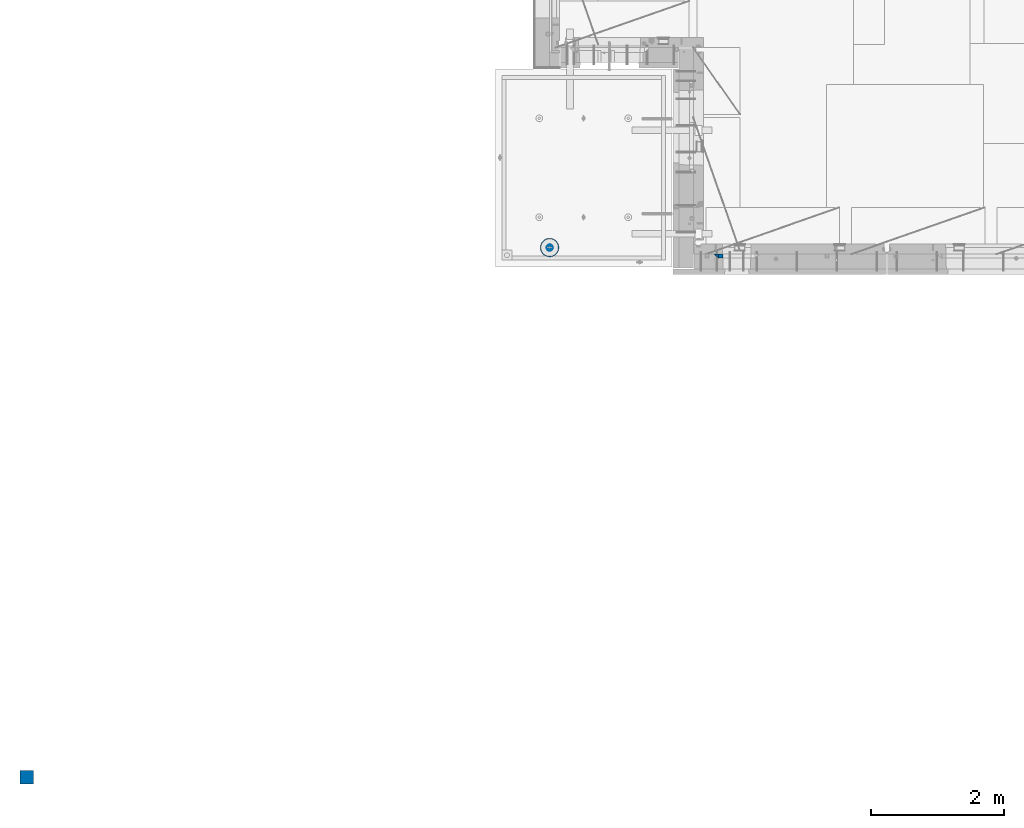
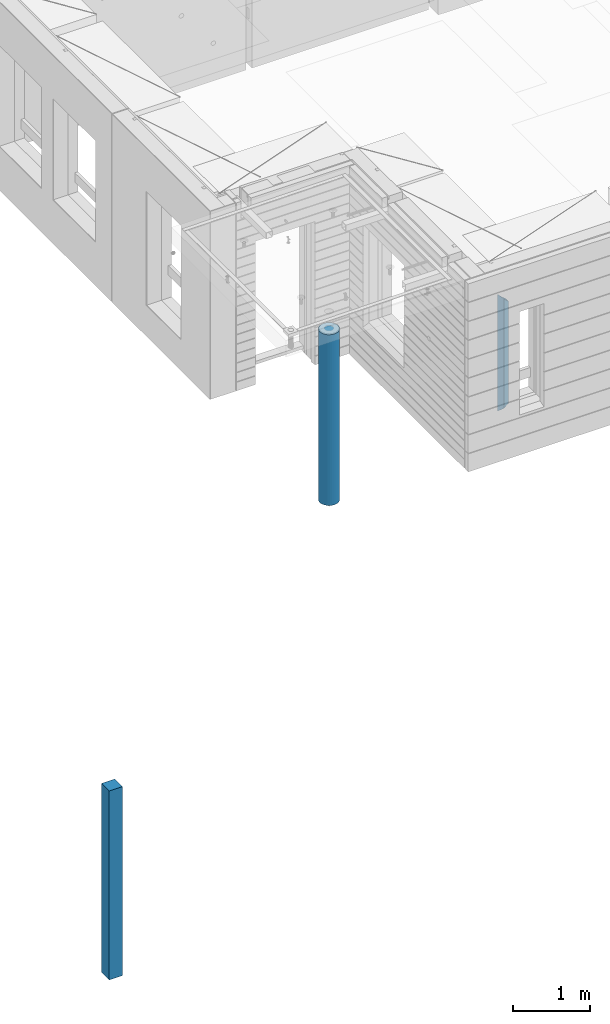
# One storey, part 1 of 341: 4 columns, 3 elements without a shape of their own.
"""IFC2X3 building model written with IfcOpenShell, lengths in millimetres."""

from ifc_helpers import new_model, si_unit, frame, origin_with_axes, place, context, subcontext, project, spatial, faceted_brep, material, type_object, element, aggregate, save


model = new_model("IFC2X3")

# Units and contexts
model_context = context("Model", 3, precision=1e-05, world=origin_with_axes())
body_context = subcontext(model_context, "Body", "Model", "MODEL_VIEW")
ifc_project = project(units=[si_unit("LENGTHUNIT", "METRE", prefix="MILLI"), si_unit("AREAUNIT", "SQUARE_METRE"), si_unit("VOLUMEUNIT", "CUBIC_METRE"), si_unit("MASSUNIT", "GRAM", prefix="KILO"), si_unit("TIMEUNIT", "SECOND"), si_unit("PLANEANGLEUNIT", "RADIAN"), si_unit("SOLIDANGLEUNIT", "STERADIAN"), si_unit("THERMODYNAMICTEMPERATUREUNIT", "DEGREE_CELSIUS"), si_unit("LUMINOUSINTENSITYUNIT", "LUMEN")], contexts=[model_context])

# Site, building, storey
site_placement = place(None, origin_with_axes())
site = spatial("IfcSite", under=ifc_project, at=site_placement, CompositionType="ELEMENT")
building_placement = place(site_placement, origin_with_axes())
building = spatial("IfcBuilding", under=site, at=building_placement, CompositionType="ELEMENT")
storey_placement = place(building_placement, origin_with_axes())
storey = spatial("IfcBuildingStorey", under=building, at=storey_placement, Name="5", CompositionType="ELEMENT", Elevation=0.0)

# Assembly, columns
assembly_1_placement = place(storey_placement, origin_with_axes())
assembly_1 = element("IfcElementAssembly", 1, at=assembly_1_placement, inside=storey, AssemblyPlace="NOTDEFINED", PredefinedType="REINFORCEMENT_UNIT")
ifc_material_1 = material(Name="CONCRETE/C25/30")
column_type_1 = type_object("IfcColumnType", PredefinedType="NOTDEFINED")
column_1_placement = place(assembly_1_placement, frame((10354.997879677, 7820.0, 94320.0), z_axis=(1.0, 0.0, 0.0), x_axis=(0.0, 0.0, 1.0)))
column_1 = element("IfcColumn", 2, at=column_1_placement, type_object=column_type_1, material=ifc_material_1, Name="SK", context=body_context, shape_type="Brep", body=[
    faceted_brep([(1795.00000000001, -30.0, 30.0), (1855.0, -30.0, -30.0), (1795.00000000001, 30.0, 30.0), (60.0000000000073, -30.0, 30.0), (0.0, -30.0, -30.0), (60.0000000000073, 30.0, 30.0)], [[[0, 1, 2]], [[1, 0, 3, 4]], [[2, 1, 4, 5]], [[0, 2, 5, 3]], [[5, 4, 3]]]),
])
column_type_2 = type_object("IfcColumnType", PredefinedType="NOTDEFINED")
column_2_placement = place(assembly_1_placement, frame((10419.997879677, 7820.0, 94380.0), z_axis=(1.0, 0.0, 0.0), x_axis=(0.0, 0.0, 1.0)))
column_2 = element("IfcColumn", 3, at=column_2_placement, type_object=column_type_2, material=ifc_material_1, Name="SK", context=body_context, shape_type="Brep", body=[
    faceted_brep([(1735.0, -30.0, -35.0), (1735.0, 30.0, -35.0), (1678.70525582272, 30.0, 30.6772015545812), (1680.09521721235, -30.0, 29.0555799329595), (56.2947441772849, 30.0, 30.6772015545812), (54.9047827876348, -30.0, 29.0555799329595), (0.0, -30.0, -35.0), (0.0, 30.0, -35.0)], [[[0, 1, 2, 3]], [[3, 2, 4, 5]], [[0, 3, 5, 6]], [[1, 0, 6, 7]], [[2, 1, 7, 4]], [[6, 5, 4, 7]]]),
])
aggregate(assembly_1, [column_1, column_2])

# Assembly, column
assembly_2_placement = place(storey_placement, origin_with_axes())
assembly_2 = element("IfcElementAssembly", 4, at=assembly_2_placement, inside=storey, AssemblyPlace="NOTDEFINED", PredefinedType="REINFORCEMENT_UNIT")
ifc_material_2 = material(Name="CONCRETE/Concrete_Undefined")
column_type_3 = type_object("IfcColumnType", PredefinedType="NOTDEFINED")
column_3_placement = place(assembly_2_placement, frame((0.0, 0.0, 93760.0), z_axis=(0.0, 1.0, 0.0), x_axis=(0.0, 0.0, 1.0)))
column_3 = element("IfcColumn", 5, at=column_3_placement, type_object=column_type_3, material=ifc_material_2, context=body_context, shape_type="Brep", body=[
    faceted_brep([(0.0, 100.0, -100.0), (0.0, 100.0, 100.0), (3000.0, 100.0, 100.0), (3000.0, 100.0, -100.0), (0.0, -100.0, 100.0), (3000.0, -100.0, 100.0), (0.0, -100.0, -100.0), (3000.0, -100.0, -100.0)], [[[0, 1, 2, 3]], [[1, 4, 5, 2]], [[4, 6, 7, 5]], [[6, 0, 3, 7]], [[5, 7, 3, 2]], [[6, 4, 1, 0]]]),
])
aggregate(assembly_2, [column_3])

assembly_3_placement = place(storey_placement, origin_with_axes())
assembly_3 = element("IfcElementAssembly", 6, at=assembly_3_placement, inside=storey, AssemblyPlace="NOTDEFINED", PredefinedType="REINFORCEMENT_UNIT")
ifc_material_3 = material(Name="CONCRETE/C30/37")
column_type_4 = type_object("IfcColumnType", Name="D280", PredefinedType="NOTDEFINED")
column_4_placement = place(assembly_3_placement, frame((7849.99879520436, 7949.98488883804, 93725.0), z_axis=(-1.0, 3.00000001838171e-08, 0.0), x_axis=(0.0, 0.0, 1.0)))
column_4 = element("IfcColumn", 7, at=column_4_placement, type_object=column_type_4, material=ifc_material_3, ObjectType="D280", context=body_context, shape_type="Brep", body=[
    faceted_brep([(0.0, -140.0, 0.0), (0.0, -136.489907705454, -31.1529307538876), (2710.0, -136.489907705454, -31.1529307538876), (2710.0, -140.0, 0.0), (0.0, -126.135641506338, -60.7437234764584), (2710.0, -126.135641506338, -60.7437234764584), (0.0, -109.456407545524, -87.2885722602223), (2710.0, -109.456407545524, -87.2885722602223), (0.0, -87.2885722602223, -109.456407545527), (2710.0, -87.2885722602223, -109.456407545527), (0.0, -60.7437234764584, -126.135641506342), (2710.0, -60.7437234764584, -126.135641506342), (0.0, -31.152930753884, -136.489907705458), (2710.0, -31.152930753884, -136.489907705458), (0.0, 0.0, -140.0), (2710.0, 0.0, -140.0), (0.0, 31.152930753884, -136.489907705458), (2710.0, 31.152930753884, -136.489907705458), (0.0, 60.7437234764584, -126.135641506342), (2710.0, 60.7437234764584, -126.135641506342), (0.0, 87.2885722602223, -109.456407545527), (2710.0, 87.2885722602223, -109.456407545527), (0.0, 109.456407545524, -87.2885722602223), (2710.0, 109.456407545524, -87.2885722602223), (0.0, 126.135641506338, -60.7437234764584), (2710.0, 126.135641506338, -60.7437234764584), (0.0, 136.489907705454, -31.1529307538876), (2710.0, 136.489907705454, -31.1529307538876), (0.0, 140.0, 0.0), (2710.0, 140.0, 0.0), (0.0, 136.489907705454, 31.1529307538876), (2710.0, 136.489907705454, 31.1529307538876), (0.0, 126.135641506338, 60.7437234764584), (2710.0, 126.135641506338, 60.7437234764584), (0.0, 109.456407545524, 87.2885722602223), (2710.0, 109.456407545524, 87.2885722602223), (0.0, 87.2885722602223, 109.456407545527), (2710.0, 87.2885722602223, 109.456407545527), (0.0, 60.7437234764584, 126.135641506342), (2710.0, 60.7437234764584, 126.135641506342), (0.0, 31.152930753884, 136.489907705458), (2710.0, 31.152930753884, 136.489907705458), (0.0, 0.0, 140.0), (2710.0, 0.0, 140.0), (0.0, -31.152930753884, 136.489907705458), (2710.0, -31.152930753884, 136.489907705458), (0.0, -60.7437234764584, 126.135641506342), (2710.0, -60.7437234764584, 126.135641506342), (0.0, -87.2885722602223, 109.456407545527), (2710.0, -87.2885722602223, 109.456407545527), (0.0, -109.456407545524, 87.2885722602223), (2710.0, -109.456407545524, 87.2885722602223), (0.0, -126.135641506338, 60.7437234764584), (2710.0, -126.135641506338, 60.7437234764584), (0.0, -136.489907705454, 31.1529307538876), (2710.0, -136.489907705454, 31.1529307538876)], [[[0, 1, 2, 3]], [[1, 4, 5, 2]], [[4, 6, 7, 5]], [[6, 8, 9, 7]], [[8, 10, 11, 9]], [[10, 12, 13, 11]], [[12, 14, 15, 13]], [[14, 16, 17, 15]], [[16, 18, 19, 17]], [[18, 20, 21, 19]], [[20, 22, 23, 21]], [[22, 24, 25, 23]], [[24, 26, 27, 25]], [[26, 28, 29, 27]], [[28, 30, 31, 29]], [[30, 32, 33, 31]], [[32, 34, 35, 33]], [[34, 36, 37, 35]], [[36, 38, 39, 37]], [[38, 40, 41, 39]], [[40, 42, 43, 41]], [[42, 44, 45, 43]], [[44, 46, 47, 45]], [[46, 48, 49, 47]], [[48, 50, 51, 49]], [[50, 52, 53, 51]], [[52, 54, 55, 53]], [[54, 0, 3, 55]], [[5, 7, 9, 11, 13, 15, 17, 19, 21, 23, 25, 27, 29, 31, 33, 35, 37, 39, 41, 43, 45, 47, 49, 51, 53, 55, 3, 2]], [[54, 52, 50, 48, 46, 44, 42, 40, 38, 36, 34, 32, 30, 28, 26, 24, 22, 20, 18, 16, 14, 12, 10, 8, 6, 4, 1, 0]]]),
])
aggregate(assembly_3, [column_4])

save(model, "model.ifc")
